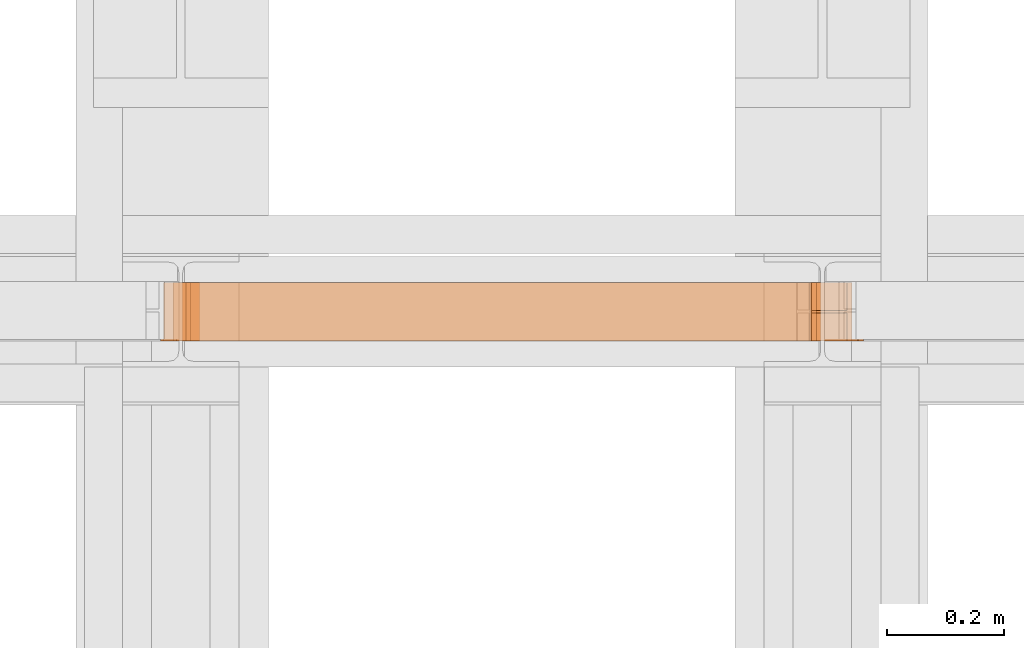
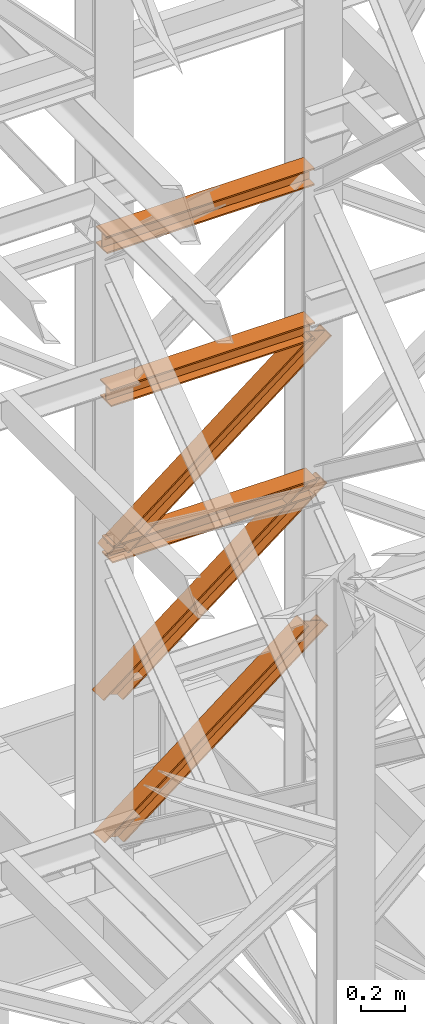
# One storey, part 173 of 208: 6 proxies.
"""IFC2X3 building model written with IfcOpenShell, lengths in millimetres."""

from ifc_helpers import new_model, entity, si_unit, converted_unit, frame, origin, origin_with_axes, place, context, subcontext, project, spatial, faceted_brep, element, save


model = new_model("IFC2X3")

# Units and contexts
model_context = context("Model", 3, precision=1e-05, world=origin())
plan_context = context("Plan", 3, precision=1e-05, world=origin())
body_context = subcontext(model_context, "Body", "Model", "MODEL_VIEW")
ifc_project = project(units=[si_unit("LENGTHUNIT", "METRE", prefix="MILLI"), converted_unit("PLANEANGLEUNIT", "DEGREE", entity("IfcPlaneAngleMeasure", 0.0174532925199433), si_unit("PLANEANGLEUNIT", "RADIAN"), dimensions=[0, 0, 0, 0, 0, 0, 0]), si_unit("AREAUNIT", "SQUARE_METRE"), si_unit("VOLUMEUNIT", "CUBIC_METRE")], contexts=[model_context, plan_context])

# Building, storey
building_placement = place(None, origin())
building = spatial("IfcBuilding", under=ifc_project, at=building_placement, CompositionType="COMPLEX")
storey_placement = place(building_placement, origin_with_axes())
storey = spatial("IfcBuildingStorey", under=building, at=storey_placement, Name="Geschoss", CompositionType="ELEMENT")

# Proxies
proxy_1_placement = place(storey_placement, frame((5458.579860905065, -13812.57439031789, 6277.169577005048), z_axis=(0.0, 0.0, 1.0), x_axis=(1.0, 0.0, 0.0)))
element("IfcBuildingElementProxy", 1, at=proxy_1_placement, inside=storey, context=body_context, shape_type="Brep", body=[
    faceted_brep([(102.1951758775585, 0.01000000000021828, 2.740588637045221), (1171.358514747175, 0.01000000000021828, 832.0088993484442), (1180.648076190588, 0.01000000000021828, 829.2783107114064), (111.4847373209723, 0.01000000000021828, 0.01000000000021828), (111.4847373209723, 0.01000000000021828, 0.01000000000021828), (1180.648076190588, 0.01000000000021828, 829.2783107114064), (1180.64807619059, 100.0100000000002, 829.2783107114064), (111.4847373209723, 100.0100000000002, 0.01000000000021828), (111.4847373209723, 100.0100000000002, 0.01000000000021828), (1180.64807619059, 100.0100000000002, 829.2783107114064), (1171.358514747175, 100.0100000000002, 832.0088993484442), (102.1951758775585, 100.0100000000002, 2.740588637045221), (102.1951758775585, 100.0100000000002, 2.740588637045221), (1171.358514747175, 100.0100000000002, 832.0088993484442), (1171.358514747175, 52.51000000000022, 832.0088993484442), (102.1951758775585, 52.51000000000022, 2.740588637045221), (102.1951758775585, 52.51000000000022, 2.740588637045221), (1171.358514747175, 52.51000000000022, 832.0088993484442), (1078.46290031303, 52.51000000000022, 859.3147857188433), (9.29956144341486, 52.51000000000022, 30.04647500744432), (9.29956144341486, 52.51000000000022, 30.04647500744432), (1078.46290031303, 52.51000000000022, 859.3147857188433), (1078.46290031303, 100.0100000000002, 859.3147857188433), (9.299561443416678, 100.0100000000002, 30.04647500744432), (9.299561443416678, 100.0100000000002, 30.04647500744432), (1078.46290031303, 100.0100000000002, 859.3147857188433), (1069.173338869616, 100.0100000000002, 862.045374355881), (0.01000000000021828, 100.0100000000002, 32.77706364448204), (0.01000000000021828, 100.0100000000002, 32.77706364448204), (1069.173338869616, 100.0100000000002, 862.045374355881), (1069.173338869616, 0.01000000000021828, 862.0453743558883), (0.01000000000021828, 0.01000000000021828, 32.77706364448204), (0.01000000000021828, 0.01000000000021828, 32.77706364448204), (1069.173338869616, 0.01000000000021828, 862.0453743558883), (1078.46290031303, 0.01000000000021828, 859.3147857188433), (9.29956144341486, 0.01000000000021828, 30.04647500744432), (9.29956144341486, 0.01000000000021828, 30.04647500744432), (1078.46290031303, 0.01000000000021828, 859.3147857188433), (1078.462900313032, 47.51000000000022, 859.3147857188433), (9.299561443416678, 47.51000000000022, 30.04647500744432), (9.299561443416678, 47.51000000000022, 30.04647500744432), (1078.462900313032, 47.51000000000022, 859.3147857188433), (1171.358514747175, 47.51000000000022, 832.0088993484442), (102.1951758775585, 47.51000000000022, 2.740588637045221), (102.1951758775585, 47.51000000000022, 2.740588637045221), (1171.358514747175, 47.51000000000022, 832.0088993484442), (1171.358514747175, 0.01000000000021828, 832.0088993484442), (102.1951758775585, 0.01000000000021828, 2.740588637045221), (1171.358514747175, 0.01000000000021828, 832.0088993484442), (1171.358514747175, 47.51000000000022, 832.0088993484442), (1078.462900313032, 47.51000000000022, 859.3147857188433), (1078.46290031303, 0.01000000000021828, 859.3147857188433), (1069.173338869616, 0.01000000000021828, 862.0453743558883), (1069.173338869616, 100.0100000000002, 862.045374355881), (1078.46290031303, 100.0100000000002, 859.3147857188433), (1078.46290031303, 52.51000000000022, 859.3147857188433), (1171.358514747175, 52.51000000000022, 832.0088993484442), (1171.358514747175, 100.0100000000002, 832.0088993484442), (1180.64807619059, 100.0100000000002, 829.2783107114064), (1180.648076190588, 0.01000000000021828, 829.2783107114064), (111.4847373209723, 0.01000000000021828, 0.01000000000021828), (111.4847373209723, 100.0100000000002, 0.01000000000021828), (102.1951758775585, 100.0100000000002, 2.740588637045221), (102.1951758775585, 52.51000000000022, 2.740588637045221), (9.29956144341486, 52.51000000000022, 30.04647500744432), (9.299561443416678, 100.0100000000002, 30.04647500744432), (0.01000000000021828, 100.0100000000002, 32.77706364448204), (0.01000000000021828, 0.01000000000021828, 32.77706364448204), (9.29956144341486, 0.01000000000021828, 30.04647500744432), (9.299561443416678, 47.51000000000022, 30.04647500744432), (102.1951758775585, 47.51000000000022, 2.740588637045221), (102.1951758775585, 0.01000000000021828, 2.740588637045221)], [[[0, 1, 2, 3]], [[4, 5, 6, 7]], [[8, 9, 10, 11]], [[12, 13, 14, 15]], [[16, 17, 18, 19]], [[20, 21, 22, 23]], [[24, 25, 26, 27]], [[28, 29, 30, 31]], [[32, 33, 34, 35]], [[36, 37, 38, 39]], [[40, 41, 42, 43]], [[44, 45, 46, 47]], [[48, 49, 50, 51, 52, 53, 54, 55, 56, 57, 58, 59]], [[60, 61, 62, 63, 64, 65, 66, 67, 68, 69, 70, 71]]], orient=[[False], [False], [False], [False], [False], [False], [False], [False], [False], [False], [False], [False], [False], [False]]),
])
proxy_2_placement = place(storey_placement, frame((5480.078845706894, -13812.50587051042, 8785.007354628784), z_axis=(0.0, 0.0, 1.0), x_axis=(1.0, 0.0, 0.0)))
element("IfcBuildingElementProxy", 2, at=proxy_2_placement, inside=storey, context=body_context, shape_type="Brep", body=[
    faceted_brep([(1091.936120735611, 0.01000000000021828, 88.01000000000022), (1091.936120735611, 0.01000000000021828, 96.01000000000022), (1091.936120735611, 100.0100000000002, 96.01000000000022), (1091.936120735611, 100.0100000000002, 88.01000000000022), (1091.936120735611, 52.51000000000022, 88.01000000000022), (1091.936120735611, 52.51000000000022, 8.010000000000218), (1091.936120735611, 100.0100000000002, 8.010000000000218), (1091.936120735611, 100.0100000000002, 0.01000000000021828), (1091.936120735611, 0.01000000000021828, 0.01000000000021828), (1091.936120735611, 0.01000000000021828, 8.010000000000218), (1091.936120735611, 47.51000000000022, 8.010000000000218), (1091.936120735611, 47.51000000000022, 88.01000000000022), (1091.936120735611, 0.01000000000021828, 96.01000000000022), (1091.936120735611, 0.01000000000021828, 88.01000000000022), (0.009999999999308784, 0.01000000000385626, 88.01000000000022), (0.009999999999308784, 0.01000000000385626, 96.01000000000022), (1091.936120735611, 100.0100000000002, 96.01000000000022), (1091.936120735611, 0.01000000000021828, 96.01000000000022), (0.009999999999308784, 0.01000000000385626, 96.01000000000022), (0.009999999999308784, 100.0100000000039, 96.01000000000022), (1091.936120735611, 100.0100000000002, 88.01000000000022), (1091.936120735611, 100.0100000000002, 96.01000000000022), (0.009999999999308784, 100.0100000000039, 96.01000000000022), (0.009999999999308784, 100.0100000000039, 88.01000000000022), (1091.936120735611, 52.51000000000022, 88.01000000000022), (1091.936120735611, 100.0100000000002, 88.01000000000022), (0.009999999999308784, 100.0100000000039, 88.01000000000022), (0.009999999999308784, 52.51000000000386, 88.01000000000022), (1091.936120735611, 52.51000000000022, 8.010000000000218), (1091.936120735611, 52.51000000000022, 88.01000000000022), (0.009999999999308784, 52.51000000000386, 88.01000000000022), (0.009999999999308784, 52.51000000000386, 8.010000000000218), (1091.936120735611, 100.0100000000002, 8.010000000000218), (1091.936120735611, 52.51000000000022, 8.010000000000218), (0.009999999999308784, 52.51000000000386, 8.010000000000218), (0.009999999999308784, 100.0100000000039, 8.010000000000218), (1091.936120735611, 100.0100000000002, 0.01000000000021828), (1091.936120735611, 100.0100000000002, 8.010000000000218), (0.009999999999308784, 100.0100000000039, 8.010000000000218), (0.009999999999308784, 100.0100000000039, 0.01000000000021828), (1091.936120735611, 0.01000000000021828, 0.01000000000021828), (1091.936120735611, 100.0100000000002, 0.01000000000021828), (0.009999999999308784, 100.0100000000039, 0.01000000000021828), (0.009999999999308784, 0.01000000000385626, 0.01000000000021828), (1091.936120735611, 0.01000000000021828, 8.010000000000218), (1091.936120735611, 0.01000000000021828, 0.01000000000021828), (0.009999999999308784, 0.01000000000385626, 0.01000000000021828), (0.009999999999308784, 0.01000000000385626, 8.010000000000218), (1091.936120735611, 47.51000000000022, 8.010000000000218), (1091.936120735611, 0.01000000000021828, 8.010000000000218), (0.009999999999308784, 0.01000000000385626, 8.010000000000218), (0.009999999999308784, 47.51000000000386, 8.010000000000218), (1091.936120735611, 47.51000000000022, 88.01000000000022), (1091.936120735611, 47.51000000000022, 8.010000000000218), (0.009999999999308784, 47.51000000000386, 8.010000000000218), (0.009999999999308784, 47.51000000000386, 88.01000000000022), (1091.936120735611, 0.01000000000021828, 88.01000000000022), (1091.936120735611, 47.51000000000022, 88.01000000000022), (0.009999999999308784, 47.51000000000386, 88.01000000000022), (0.009999999999308784, 0.01000000000385626, 88.01000000000022), (0.009999999999308784, 0.01000000000385626, 88.01000000000022), (0.009999999999308784, 47.51000000000386, 88.01000000000022), (0.009999999999308784, 47.51000000000386, 8.010000000000218), (0.009999999999308784, 0.01000000000385626, 8.010000000000218), (0.009999999999308784, 0.01000000000385626, 0.01000000000021828), (0.009999999999308784, 100.0100000000039, 0.01000000000021828), (0.009999999999308784, 100.0100000000039, 8.010000000000218), (0.009999999999308784, 52.51000000000386, 8.010000000000218), (0.009999999999308784, 52.51000000000386, 88.01000000000022), (0.009999999999308784, 100.0100000000039, 88.01000000000022), (0.009999999999308784, 100.0100000000039, 96.01000000000022), (0.009999999999308784, 0.01000000000385626, 96.01000000000022)], [[[0, 1, 2, 3, 4, 5, 6, 7, 8, 9, 10, 11]], [[12, 13, 14, 15]], [[16, 17, 18, 19]], [[20, 21, 22, 23]], [[24, 25, 26, 27]], [[28, 29, 30, 31]], [[32, 33, 34, 35]], [[36, 37, 38, 39]], [[40, 41, 42, 43]], [[44, 45, 46, 47]], [[48, 49, 50, 51]], [[52, 53, 54, 55]], [[56, 57, 58, 59]], [[60, 61, 62, 63, 64, 65, 66, 67, 68, 69, 70, 71]]], orient=[[False], [False], [False], [False], [False], [False], [False], [False], [False], [False], [False], [False], [False], [False]]),
])
proxy_3_placement = place(storey_placement, frame((5486.281894347278, -13812.57439031789, 7083.7003024192), z_axis=(0.0, 0.0, 1.0), x_axis=(1.0, 0.0, 0.0)))
element("IfcBuildingElementProxy", 3, at=proxy_3_placement, inside=storey, context=body_context, shape_type="Brep", body=[
    faceted_brep([(102.3304620042309, 0.01000000000021828, 2.698394179888055), (1167.71864773611, 0.01000000000021828, 836.8112103120347), (1177.020507918311, 0.01000000000021828, 834.1228161321469), (111.6323221864332, 0.01000000000021828, 0.01000000000021828), (111.6323221864332, 0.01000000000021828, 0.01000000000021828), (1177.020507918311, 0.01000000000021828, 834.1228161321469), (1177.020507918312, 100.0100000000002, 834.1228161321469), (111.6323221864332, 100.0100000000002, 0.01000000000021828), (111.6323221864332, 100.0100000000002, 0.01000000000021828), (1177.020507918312, 100.0100000000002, 834.1228161321469), (1167.71864773611, 100.0100000000002, 836.8112103120347), (102.3304620042309, 100.0100000000002, 2.698394179888055), (102.3304620042309, 100.0100000000002, 2.698394179888055), (1167.71864773611, 100.0100000000002, 836.8112103120347), (1167.71864773611, 52.51000000000022, 836.8112103120347), (102.3304620042309, 52.51000000000022, 2.698394179888055), (102.3304620042309, 52.51000000000022, 2.698394179888055), (1167.71864773611, 52.51000000000022, 836.8112103120347), (1074.70004591408, 52.51000000000022, 863.6951521109131), (9.311860182202508, 52.51000000000022, 29.58233597875915), (9.311860182202508, 52.51000000000022, 29.58233597875915), (1074.70004591408, 52.51000000000022, 863.6951521109131), (1074.70004591408, 100.0100000000002, 863.6951521109131), (9.311860182204327, 100.0100000000002, 29.58233597875915), (9.311860182204327, 100.0100000000002, 29.58233597875915), (1074.70004591408, 100.0100000000002, 863.6951521109131), (1065.398185731876, 100.0100000000002, 866.3835462907937), (0.01000000000021828, 100.0100000000002, 32.27073015864698), (0.01000000000021828, 100.0100000000002, 32.27073015864698), (1065.398185731876, 100.0100000000002, 866.3835462907937), (1065.398185731878, 0.01000000000021828, 866.383546290801), (0.01000000000021828, 0.01000000000021828, 32.27073015864698), (0.01000000000021828, 0.01000000000021828, 32.27073015864698), (1065.398185731878, 0.01000000000021828, 866.383546290801), (1074.70004591408, 0.01000000000021828, 863.6951521109131), (9.311860182202508, 0.01000000000021828, 29.58233597875915), (9.311860182202508, 0.01000000000021828, 29.58233597875915), (1074.70004591408, 0.01000000000021828, 863.6951521109131), (1074.700045914082, 47.51000000000022, 863.6951521109131), (9.311860182204327, 47.51000000000022, 29.58233597875915), (9.311860182204327, 47.51000000000022, 29.58233597875915), (1074.700045914082, 47.51000000000022, 863.6951521109131), (1167.71864773611, 47.51000000000022, 836.8112103120347), (102.3304620042309, 47.51000000000022, 2.698394179888055), (102.3304620042309, 47.51000000000022, 2.698394179888055), (1167.71864773611, 47.51000000000022, 836.8112103120347), (1167.71864773611, 0.01000000000021828, 836.8112103120347), (102.3304620042309, 0.01000000000021828, 2.698394179888055), (1167.71864773611, 0.01000000000021828, 836.8112103120347), (1167.71864773611, 47.51000000000022, 836.8112103120347), (1074.700045914082, 47.51000000000022, 863.6951521109131), (1074.70004591408, 0.01000000000021828, 863.6951521109131), (1065.398185731878, 0.01000000000021828, 866.383546290801), (1065.398185731876, 100.0100000000002, 866.3835462907937), (1074.70004591408, 100.0100000000002, 863.6951521109131), (1074.70004591408, 52.51000000000022, 863.6951521109131), (1167.71864773611, 52.51000000000022, 836.8112103120347), (1167.71864773611, 100.0100000000002, 836.8112103120347), (1177.020507918312, 100.0100000000002, 834.1228161321469), (1177.020507918311, 0.01000000000021828, 834.1228161321469), (111.6323221864332, 0.01000000000021828, 0.01000000000021828), (111.6323221864332, 100.0100000000002, 0.01000000000021828), (102.3304620042309, 100.0100000000002, 2.698394179888055), (102.3304620042309, 52.51000000000022, 2.698394179888055), (9.311860182202508, 52.51000000000022, 29.58233597875915), (9.311860182204327, 100.0100000000002, 29.58233597875915), (0.01000000000021828, 100.0100000000002, 32.27073015864698), (0.01000000000021828, 0.01000000000021828, 32.27073015864698), (9.311860182202508, 0.01000000000021828, 29.58233597875915), (9.311860182204327, 47.51000000000022, 29.58233597875915), (102.3304620042309, 47.51000000000022, 2.698394179888055), (102.3304620042309, 0.01000000000021828, 2.698394179888055)], [[[0, 1, 2, 3]], [[4, 5, 6, 7]], [[8, 9, 10, 11]], [[12, 13, 14, 15]], [[16, 17, 18, 19]], [[20, 21, 22, 23]], [[24, 25, 26, 27]], [[28, 29, 30, 31]], [[32, 33, 34, 35]], [[36, 37, 38, 39]], [[40, 41, 42, 43]], [[44, 45, 46, 47]], [[48, 49, 50, 51, 52, 53, 54, 55, 56, 57, 58, 59]], [[60, 61, 62, 63, 64, 65, 66, 67, 68, 69, 70, 71]]], orient=[[False], [False], [False], [False], [False], [False], [False], [False], [False], [False], [False], [False], [False], [False]]),
])
proxy_4_placement = place(storey_placement, frame((5463.425086811947, -13812.57439031789, 5483.427996514323), z_axis=(0.0, 0.0, 1.0), x_axis=(1.0, 0.0, 0.0)))
element("IfcBuildingElementProxy", 4, at=proxy_4_placement, inside=storey, context=body_context, shape_type="Brep", body=[
    faceted_brep([(102.1951758775585, 0.01000000000021828, 2.740588637045221), (1171.358514747175, 0.01000000000021828, 832.0088993484442), (1180.648076190588, 0.01000000000021828, 829.2783107114064), (111.4847373209723, 0.01000000000021828, 0.01000000000021828), (111.4847373209723, 0.01000000000021828, 0.01000000000021828), (1180.648076190588, 0.01000000000021828, 829.2783107114064), (1180.64807619059, 100.0100000000002, 829.2783107114064), (111.4847373209723, 100.0100000000002, 0.01000000000021828), (111.4847373209723, 100.0100000000002, 0.01000000000021828), (1180.64807619059, 100.0100000000002, 829.2783107114064), (1171.358514747175, 100.0100000000002, 832.0088993484442), (102.1951758775585, 100.0100000000002, 2.740588637045221), (102.1951758775585, 100.0100000000002, 2.740588637045221), (1171.358514747175, 100.0100000000002, 832.0088993484442), (1171.358514747175, 52.51000000000022, 832.0088993484442), (102.1951758775585, 52.51000000000022, 2.740588637045221), (102.1951758775585, 52.51000000000022, 2.740588637045221), (1171.358514747175, 52.51000000000022, 832.0088993484442), (1078.46290031303, 52.51000000000022, 859.3147857188433), (9.29956144341486, 52.51000000000022, 30.04647500744432), (9.29956144341486, 52.51000000000022, 30.04647500744432), (1078.46290031303, 52.51000000000022, 859.3147857188433), (1078.46290031303, 100.0100000000002, 859.3147857188433), (9.299561443416678, 100.0100000000002, 30.04647500744432), (9.299561443416678, 100.0100000000002, 30.04647500744432), (1078.46290031303, 100.0100000000002, 859.3147857188433), (1069.173338869616, 100.0100000000002, 862.045374355881), (0.01000000000021828, 100.0100000000002, 32.77706364448204), (0.01000000000021828, 100.0100000000002, 32.77706364448204), (1069.173338869616, 100.0100000000002, 862.045374355881), (1069.173338869616, 0.01000000000021828, 862.0453743558883), (0.01000000000021828, 0.01000000000021828, 32.77706364448204), (0.01000000000021828, 0.01000000000021828, 32.77706364448204), (1069.173338869616, 0.01000000000021828, 862.0453743558883), (1078.46290031303, 0.01000000000021828, 859.3147857188433), (9.29956144341486, 0.01000000000021828, 30.04647500744432), (9.29956144341486, 0.01000000000021828, 30.04647500744432), (1078.46290031303, 0.01000000000021828, 859.3147857188433), (1078.462900313032, 47.51000000000022, 859.3147857188433), (9.299561443416678, 47.51000000000022, 30.04647500744432), (9.299561443416678, 47.51000000000022, 30.04647500744432), (1078.462900313032, 47.51000000000022, 859.3147857188433), (1171.358514747175, 47.51000000000022, 832.0088993484442), (102.1951758775585, 47.51000000000022, 2.740588637045221), (102.1951758775585, 47.51000000000022, 2.740588637045221), (1171.358514747175, 47.51000000000022, 832.0088993484442), (1171.358514747175, 0.01000000000021828, 832.0088993484442), (102.1951758775585, 0.01000000000021828, 2.740588637045221), (1171.358514747175, 0.01000000000021828, 832.0088993484442), (1171.358514747175, 47.51000000000022, 832.0088993484442), (1078.462900313032, 47.51000000000022, 859.3147857188433), (1078.46290031303, 0.01000000000021828, 859.3147857188433), (1069.173338869616, 0.01000000000021828, 862.0453743558883), (1069.173338869616, 100.0100000000002, 862.045374355881), (1078.46290031303, 100.0100000000002, 859.3147857188433), (1078.46290031303, 52.51000000000022, 859.3147857188433), (1171.358514747175, 52.51000000000022, 832.0088993484442), (1171.358514747175, 100.0100000000002, 832.0088993484442), (1180.64807619059, 100.0100000000002, 829.2783107114064), (1180.648076190588, 0.01000000000021828, 829.2783107114064), (111.4847373209723, 0.01000000000021828, 0.01000000000021828), (111.4847373209723, 100.0100000000002, 0.01000000000021828), (102.1951758775585, 100.0100000000002, 2.740588637045221), (102.1951758775585, 52.51000000000022, 2.740588637045221), (9.29956144341486, 52.51000000000022, 30.04647500744432), (9.299561443416678, 100.0100000000002, 30.04647500744432), (0.01000000000021828, 100.0100000000002, 32.77706364448204), (0.01000000000021828, 0.01000000000021828, 32.77706364448204), (9.29956144341486, 0.01000000000021828, 30.04647500744432), (9.299561443416678, 47.51000000000022, 30.04647500744432), (102.1951758775585, 47.51000000000022, 2.740588637045221), (102.1951758775585, 0.01000000000021828, 2.740588637045221)], [[[0, 1, 2, 3]], [[4, 5, 6, 7]], [[8, 9, 10, 11]], [[12, 13, 14, 15]], [[16, 17, 18, 19]], [[20, 21, 22, 23]], [[24, 25, 26, 27]], [[28, 29, 30, 31]], [[32, 33, 34, 35]], [[36, 37, 38, 39]], [[40, 41, 42, 43]], [[44, 45, 46, 47]], [[48, 49, 50, 51, 52, 53, 54, 55, 56, 57, 58, 59]], [[60, 61, 62, 63, 64, 65, 66, 67, 68, 69, 70, 71]]], orient=[[False], [False], [False], [False], [False], [False], [False], [False], [False], [False], [False], [False], [False], [False]]),
])
proxy_5_placement = place(storey_placement, frame((5501.832093855034, -13812.50587051042, 7926.310598775423), z_axis=(0.0, 0.0, 1.0), x_axis=(1.0, 0.0, 0.0)))
element("IfcBuildingElementProxy", 5, at=proxy_5_placement, inside=storey, context=body_context, shape_type="Brep", body=[
    faceted_brep([(1072.594465339767, 0.01000000000021828, 88.01000000000022), (1072.594465339767, 0.01000000000021828, 96.01000000000022), (1072.594465339767, 100.0100000000002, 96.01000000000022), (1072.594465339767, 100.0100000000002, 88.01000000000022), (1072.594465339767, 52.51000000000022, 88.01000000000022), (1072.594465339767, 52.51000000000022, 8.010000000000218), (1072.594465339767, 100.0100000000002, 8.010000000000218), (1072.594465339767, 100.0100000000002, 0.01000000000021828), (1072.594465339767, 0.01000000000021828, 0.01000000000021828), (1072.594465339767, 0.01000000000021828, 8.010000000000218), (1072.594465339767, 47.51000000000022, 8.010000000000218), (1072.594465339767, 47.51000000000022, 88.01000000000022), (1072.594465339767, 0.01000000000021828, 96.01000000000022), (1072.594465339767, 0.01000000000021828, 88.01000000000022), (0.01000000000021828, 0.01000000000385626, 88.01000000000022), (0.01000000000021828, 0.01000000000385626, 96.01000000000022), (1072.594465339767, 100.0100000000002, 96.01000000000022), (1072.594465339767, 0.01000000000021828, 96.01000000000022), (0.01000000000021828, 0.01000000000385626, 96.01000000000022), (0.01000000000021828, 100.0100000000039, 96.01000000000022), (1072.594465339767, 100.0100000000002, 88.01000000000022), (1072.594465339767, 100.0100000000002, 96.01000000000022), (0.01000000000021828, 100.0100000000039, 96.01000000000022), (0.01000000000021828, 100.0100000000039, 88.01000000000022), (1072.594465339767, 52.51000000000022, 88.01000000000022), (1072.594465339767, 100.0100000000002, 88.01000000000022), (0.01000000000021828, 100.0100000000039, 88.01000000000022), (0.01000000000021828, 52.51000000000386, 88.01000000000022), (1072.594465339767, 52.51000000000022, 8.010000000000218), (1072.594465339767, 52.51000000000022, 88.01000000000022), (0.01000000000021828, 52.51000000000386, 88.01000000000022), (0.01000000000021828, 52.51000000000386, 8.010000000000218), (1072.594465339767, 100.0100000000002, 8.010000000000218), (1072.594465339767, 52.51000000000022, 8.010000000000218), (0.01000000000021828, 52.51000000000386, 8.010000000000218), (0.01000000000021828, 100.0100000000039, 8.010000000000218), (1072.594465339767, 100.0100000000002, 0.01000000000021828), (1072.594465339767, 100.0100000000002, 8.010000000000218), (0.01000000000021828, 100.0100000000039, 8.010000000000218), (0.01000000000021828, 100.0100000000039, 0.01000000000021828), (1072.594465339767, 0.01000000000021828, 0.01000000000021828), (1072.594465339767, 100.0100000000002, 0.01000000000021828), (0.01000000000021828, 100.0100000000039, 0.01000000000021828), (0.01000000000021828, 0.01000000000385626, 0.01000000000021828), (1072.594465339767, 0.01000000000021828, 8.010000000000218), (1072.594465339767, 0.01000000000021828, 0.01000000000021828), (0.01000000000021828, 0.01000000000385626, 0.01000000000021828), (0.01000000000021828, 0.01000000000385626, 8.010000000000218), (1072.594465339767, 47.51000000000022, 8.010000000000218), (1072.594465339767, 0.01000000000021828, 8.010000000000218), (0.01000000000021828, 0.01000000000385626, 8.010000000000218), (0.01000000000021828, 47.51000000000386, 8.010000000000218), (1072.594465339767, 47.51000000000022, 88.01000000000022), (1072.594465339767, 47.51000000000022, 8.010000000000218), (0.01000000000021828, 47.51000000000386, 8.010000000000218), (0.01000000000021828, 47.51000000000386, 88.01000000000022), (1072.594465339767, 0.01000000000021828, 88.01000000000022), (1072.594465339767, 47.51000000000022, 88.01000000000022), (0.01000000000021828, 47.51000000000386, 88.01000000000022), (0.01000000000021828, 0.01000000000385626, 88.01000000000022), (0.01000000000021828, 0.01000000000385626, 88.01000000000022), (0.01000000000021828, 47.51000000000386, 88.01000000000022), (0.01000000000021828, 47.51000000000386, 8.010000000000218), (0.01000000000021828, 0.01000000000385626, 8.010000000000218), (0.01000000000021828, 0.01000000000385626, 0.01000000000021828), (0.01000000000021828, 100.0100000000039, 0.01000000000021828), (0.01000000000021828, 100.0100000000039, 8.010000000000218), (0.01000000000021828, 52.51000000000386, 8.010000000000218), (0.01000000000021828, 52.51000000000386, 88.01000000000022), (0.01000000000021828, 100.0100000000039, 88.01000000000022), (0.01000000000021828, 100.0100000000039, 96.01000000000022), (0.01000000000021828, 0.01000000000385626, 96.01000000000022)], [[[0, 1, 2, 3, 4, 5, 6, 7, 8, 9, 10, 11]], [[12, 13, 14, 15]], [[16, 17, 18, 19]], [[20, 21, 22, 23]], [[24, 25, 26, 27]], [[28, 29, 30, 31]], [[32, 33, 34, 35]], [[36, 37, 38, 39]], [[40, 41, 42, 43]], [[44, 45, 46, 47]], [[48, 49, 50, 51]], [[52, 53, 54, 55]], [[56, 57, 58, 59]], [[60, 61, 62, 63, 64, 65, 66, 67, 68, 69, 70, 71]]], orient=[[False], [False], [False], [False], [False], [False], [False], [False], [False], [False], [False], [False], [False], [False]]),
])
proxy_6_placement = place(storey_placement, frame((5510.286475009543, -13812.50587051042, 7054.100276335031), z_axis=(0.0, 0.0, 1.0), x_axis=(1.0, 0.0, 0.0)))
element("IfcBuildingElementProxy", 6, at=proxy_6_placement, inside=storey, context=body_context, shape_type="Brep", body=[
    faceted_brep([(1072.594465339767, 0.01000000000021828, 88.01000000000022), (1072.594465339767, 0.01000000000021828, 96.01000000000022), (1072.594465339767, 100.0100000000002, 96.01000000000022), (1072.594465339767, 100.0100000000002, 88.01000000000022), (1072.594465339767, 52.51000000000022, 88.01000000000022), (1072.594465339767, 52.51000000000022, 8.010000000000218), (1072.594465339767, 100.0100000000002, 8.010000000000218), (1072.594465339767, 100.0100000000002, 0.01000000000021828), (1072.594465339767, 0.01000000000021828, 0.01000000000021828), (1072.594465339767, 0.01000000000021828, 8.010000000000218), (1072.594465339767, 47.51000000000022, 8.010000000000218), (1072.594465339767, 47.51000000000022, 88.01000000000022), (1072.594465339767, 0.01000000000021828, 96.01000000000022), (1072.594465339767, 0.01000000000021828, 88.01000000000022), (0.01000000000021828, 0.01000000000385626, 88.01000000000022), (0.01000000000021828, 0.01000000000385626, 96.01000000000022), (1072.594465339767, 100.0100000000002, 96.01000000000022), (1072.594465339767, 0.01000000000021828, 96.01000000000022), (0.01000000000021828, 0.01000000000385626, 96.01000000000022), (0.01000000000021828, 100.0100000000039, 96.01000000000022), (1072.594465339767, 100.0100000000002, 88.01000000000022), (1072.594465339767, 100.0100000000002, 96.01000000000022), (0.01000000000021828, 100.0100000000039, 96.01000000000022), (0.01000000000021828, 100.0100000000039, 88.01000000000022), (1072.594465339767, 52.51000000000022, 88.01000000000022), (1072.594465339767, 100.0100000000002, 88.01000000000022), (0.01000000000021828, 100.0100000000039, 88.01000000000022), (0.01000000000021828, 52.51000000000386, 88.01000000000022), (1072.594465339767, 52.51000000000022, 8.010000000000218), (1072.594465339767, 52.51000000000022, 88.01000000000022), (0.01000000000021828, 52.51000000000386, 88.01000000000022), (0.01000000000021828, 52.51000000000386, 8.010000000000218), (1072.594465339767, 100.0100000000002, 8.010000000000218), (1072.594465339767, 52.51000000000022, 8.010000000000218), (0.01000000000021828, 52.51000000000386, 8.010000000000218), (0.01000000000021828, 100.0100000000039, 8.010000000000218), (1072.594465339767, 100.0100000000002, 0.01000000000021828), (1072.594465339767, 100.0100000000002, 8.010000000000218), (0.01000000000021828, 100.0100000000039, 8.010000000000218), (0.01000000000021828, 100.0100000000039, 0.01000000000021828), (1072.594465339767, 0.01000000000021828, 0.01000000000021828), (1072.594465339767, 100.0100000000002, 0.01000000000021828), (0.01000000000021828, 100.0100000000039, 0.01000000000021828), (0.01000000000021828, 0.01000000000385626, 0.01000000000021828), (1072.594465339767, 0.01000000000021828, 8.010000000000218), (1072.594465339767, 0.01000000000021828, 0.01000000000021828), (0.01000000000021828, 0.01000000000385626, 0.01000000000021828), (0.01000000000021828, 0.01000000000385626, 8.010000000000218), (1072.594465339767, 47.51000000000022, 8.010000000000218), (1072.594465339767, 0.01000000000021828, 8.010000000000218), (0.01000000000021828, 0.01000000000385626, 8.010000000000218), (0.01000000000021828, 47.51000000000386, 8.010000000000218), (1072.594465339767, 47.51000000000022, 88.01000000000022), (1072.594465339767, 47.51000000000022, 8.010000000000218), (0.01000000000021828, 47.51000000000386, 8.010000000000218), (0.01000000000021828, 47.51000000000386, 88.01000000000022), (1072.594465339767, 0.01000000000021828, 88.01000000000022), (1072.594465339767, 47.51000000000022, 88.01000000000022), (0.01000000000021828, 47.51000000000386, 88.01000000000022), (0.01000000000021828, 0.01000000000385626, 88.01000000000022), (0.01000000000021828, 0.01000000000385626, 88.01000000000022), (0.01000000000021828, 47.51000000000386, 88.01000000000022), (0.01000000000021828, 47.51000000000386, 8.010000000000218), (0.01000000000021828, 0.01000000000385626, 8.010000000000218), (0.01000000000021828, 0.01000000000385626, 0.01000000000021828), (0.01000000000021828, 100.0100000000039, 0.01000000000021828), (0.01000000000021828, 100.0100000000039, 8.010000000000218), (0.01000000000021828, 52.51000000000386, 8.010000000000218), (0.01000000000021828, 52.51000000000386, 88.01000000000022), (0.01000000000021828, 100.0100000000039, 88.01000000000022), (0.01000000000021828, 100.0100000000039, 96.01000000000022), (0.01000000000021828, 0.01000000000385626, 96.01000000000022)], [[[0, 1, 2, 3, 4, 5, 6, 7, 8, 9, 10, 11]], [[12, 13, 14, 15]], [[16, 17, 18, 19]], [[20, 21, 22, 23]], [[24, 25, 26, 27]], [[28, 29, 30, 31]], [[32, 33, 34, 35]], [[36, 37, 38, 39]], [[40, 41, 42, 43]], [[44, 45, 46, 47]], [[48, 49, 50, 51]], [[52, 53, 54, 55]], [[56, 57, 58, 59]], [[60, 61, 62, 63, 64, 65, 66, 67, 68, 69, 70, 71]]], orient=[[False], [False], [False], [False], [False], [False], [False], [False], [False], [False], [False], [False], [False], [False]]),
])

save(model, "model.ifc")
